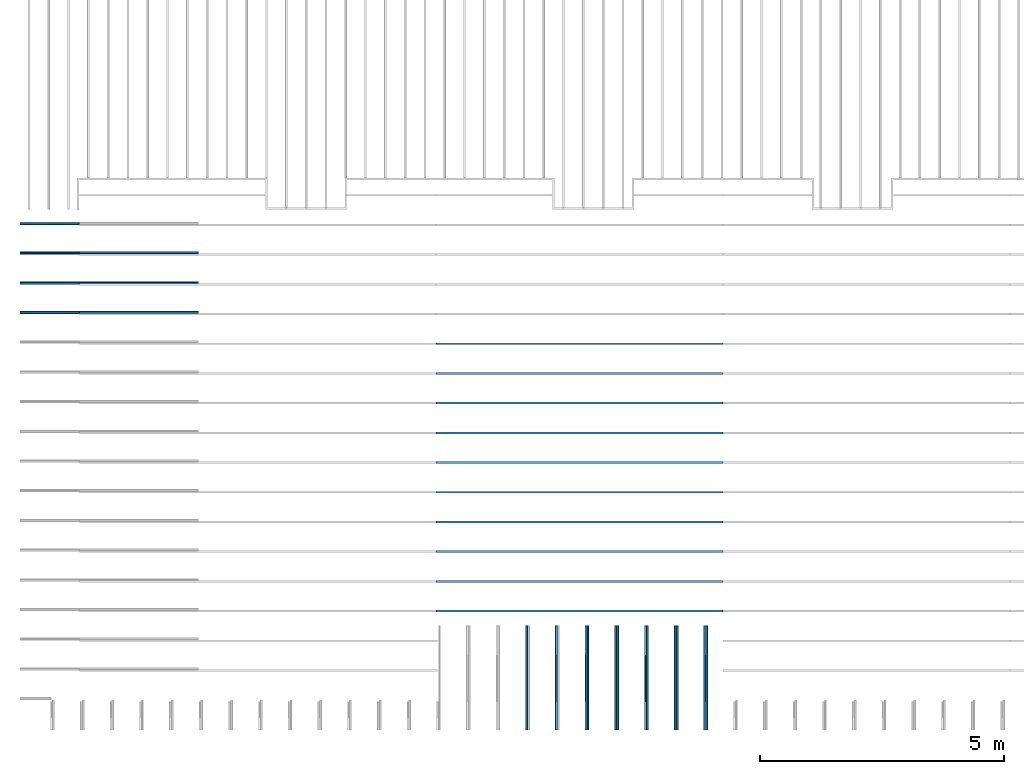
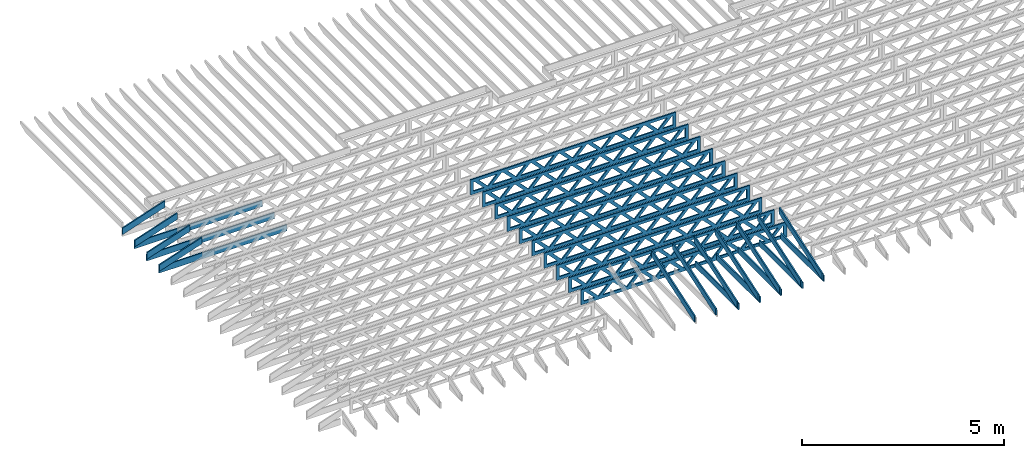
# One storey, part 3 of 17: 29 beams, 5 elements without a shape of their own.
"""IFC4 building model written with IfcOpenShell, lengths in feet."""

from ifc_helpers import new_model, entity, si_unit, converted_unit, derived_unit, direction, frame, frame_2d, origin, origin_2d_with_axis, place, context, subcontext, project, spatial, rectangle, extrude, clip, halfspace, source, transform, mapped, material, material_profile, profile_set, profile_usage, type_object, type_shapes, element, aggregate, save


model = new_model("IFC4")

# Units and contexts
model_context = context("Model", 3, precision=0.0001, world=origin(), true_north=direction((6.12303176911189e-17, 1.0)))
body_context = subcontext(model_context, "Body", "Model", "MODEL_VIEW")
ifc_project = project(units=[converted_unit("LENGTHUNIT", "FOOT", entity("IfcRatioMeasure", 0.3048), si_unit("LENGTHUNIT", "METRE"), dimensions=[1, 0, 0, 0, 0, 0, 0]), converted_unit("AREAUNIT", "SQUARE FOOT", entity("IfcRatioMeasure", 0.09290304), si_unit("AREAUNIT", "SQUARE_METRE"), dimensions=[2, 0, 0, 0, 0, 0, 0]), converted_unit("VOLUMEUNIT", "CUBIC FOOT", entity("IfcRatioMeasure", 0.028316846592), si_unit("VOLUMEUNIT", "CUBIC_METRE"), dimensions=[3, 0, 0, 0, 0, 0, 0]), converted_unit("PLANEANGLEUNIT", "DEGREE", entity("IfcRatioMeasure", 0.0174532925199433), si_unit("PLANEANGLEUNIT", "RADIAN"), dimensions=[0, 0, 0, 0, 0, 0, 0]), si_unit("MASSUNIT", "GRAM", prefix="KILO"), derived_unit("MASSDENSITYUNIT", [(si_unit("MASSUNIT", "GRAM", prefix="KILO"), 1), (si_unit("LENGTHUNIT", "METRE"), -3)]), derived_unit("MOMENTOFINERTIAUNIT", [(si_unit("LENGTHUNIT", "METRE"), 4)]), si_unit("TIMEUNIT", "SECOND"), si_unit("FREQUENCYUNIT", "HERTZ"), si_unit("THERMODYNAMICTEMPERATUREUNIT", "DEGREE_CELSIUS"), derived_unit("THERMALTRANSMITTANCEUNIT", [(si_unit("MASSUNIT", "GRAM", prefix="KILO"), 1), (si_unit("THERMODYNAMICTEMPERATUREUNIT", "KELVIN"), -1), (si_unit("TIMEUNIT", "SECOND"), -3)]), derived_unit("VOLUMETRICFLOWRATEUNIT", [(si_unit("LENGTHUNIT", "METRE"), 3), (si_unit("TIMEUNIT", "SECOND"), -1)]), si_unit("ELECTRICCURRENTUNIT", "AMPERE"), si_unit("ELECTRICVOLTAGEUNIT", "VOLT"), si_unit("POWERUNIT", "WATT"), si_unit("FORCEUNIT", "NEWTON"), si_unit("ILLUMINANCEUNIT", "LUX"), si_unit("LUMINOUSFLUXUNIT", "LUMEN"), si_unit("LUMINOUSINTENSITYUNIT", "CANDELA"), derived_unit("USERDEFINED", [(si_unit("MASSUNIT", "GRAM", prefix="KILO"), -1), (si_unit("LENGTHUNIT", "METRE"), -2), (si_unit("TIMEUNIT", "SECOND"), 3), (si_unit("LUMINOUSFLUXUNIT", "LUMEN"), 1)]), derived_unit("LINEARVELOCITYUNIT", [(si_unit("LENGTHUNIT", "METRE"), 1), (si_unit("TIMEUNIT", "SECOND"), -1)]), si_unit("PRESSUREUNIT", "PASCAL"), derived_unit("USERDEFINED", [(si_unit("LENGTHUNIT", "METRE"), -2), (si_unit("MASSUNIT", "GRAM", prefix="KILO"), 1), (si_unit("TIMEUNIT", "SECOND"), -2)]), derived_unit("LINEARFORCEUNIT", [(si_unit("MASSUNIT", "GRAM", prefix="KILO"), 1), (si_unit("LENGTHUNIT", "METRE"), 1), (si_unit("TIMEUNIT", "SECOND"), -2), (si_unit("LENGTHUNIT", "METRE"), -1)]), derived_unit("PLANARFORCEUNIT", [(si_unit("MASSUNIT", "GRAM", prefix="KILO"), 1), (si_unit("LENGTHUNIT", "METRE"), 1), (si_unit("TIMEUNIT", "SECOND"), -2), (si_unit("LENGTHUNIT", "METRE"), -2)])], contexts=[model_context])

# Site, building, storey
site_placement = place(None, origin())
site = spatial("IfcSite", under=ifc_project, at=site_placement, CompositionType="ELEMENT")
building_placement = place(site_placement, origin())
building = spatial("IfcBuilding", under=site, at=building_placement, CompositionType="ELEMENT")
storey_placement = place(building_placement, frame((0.0, 0.0, 30.4375000000082)))
storey = spatial("IfcBuildingStorey", under=building, at=storey_placement, Name="ROOF", CompositionType="ELEMENT", Elevation=30.4375000000082)

# Assembly, beams
assembly_1_placement = place(storey_placement, origin())
assembly_1 = element("IfcElementAssembly", 1, at=assembly_1_placement, inside=storey, Name="Structural Beam System:Structural Framing System", ObjectType="Structural Beam System:Structural Framing System", AssemblyPlace="NOTDEFINED", PredefinedType="BEAM_GRID")
ifc_material_1 = material(Name="WOOD TRUSS", Category="Materials")
ifc_material_profile_1 = material_profile(ifc_material_1, rectangle(XDim=1.73473973950632, YDim=0.125, at=origin_2d_with_axis()))
ifc_material_profile_2 = material_profile(ifc_material_1, rectangle(XDim=1.73473973950633, YDim=0.125, at=frame_2d((-1.11022302462516e-16, 0.0), x_axis=(1.0, 0.0))))
ifc_material_profile_3 = material_profile(ifc_material_1, rectangle(XDim=1.73473973950632, YDim=0.125, at=origin_2d_with_axis()))
ifc_material_profile_4 = material_profile(ifc_material_1, rectangle(XDim=1.73473973950633, YDim=0.125, at=origin_2d_with_axis()))
ifc_material_profile_5 = material_profile(ifc_material_1, rectangle(XDim=1.73473973950632, YDim=0.125, at=frame_2d((-5.55111512312578e-17, 0.0), x_axis=(1.0, 0.0))))
ifc_material_profile_6 = material_profile(ifc_material_1, rectangle(XDim=1.73473973950633, YDim=0.125, at=frame_2d((-2.77555756156289e-16, 0.0), x_axis=(1.0, 0.0))))
ifc_material_profile_7 = material_profile(ifc_material_1, rectangle(XDim=1.73473973950632, YDim=0.125, at=frame_2d((-4.9960036108132e-16, 0.0), x_axis=(1.0, 0.0))))
ifc_material_profile_8 = material_profile(ifc_material_1, rectangle(XDim=1.73473973950633, YDim=0.125, at=frame_2d((4.44089209850063e-16, 0.0), x_axis=(1.0, 0.0))))
ifc_material_profile_9 = material_profile(ifc_material_1, rectangle(XDim=1.73473973950632, YDim=0.125, at=origin_2d_with_axis()))
ifc_material_profile_10 = material_profile(ifc_material_1, rectangle(XDim=1.73473973950633, YDim=0.125, at=frame_2d((-4.9960036108132e-16, 0.0), x_axis=(1.0, 0.0))))
ifc_material_profile_11 = material_profile(ifc_material_1, rectangle(XDim=0.291666666666664, YDim=0.125, at=frame_2d((-2.77555756156289e-17, 0.0), x_axis=(1.0, 0.0))))
ifc_material_profile_12 = material_profile(ifc_material_1, rectangle(XDim=0.291666666666628, YDim=0.124999999999995, at=frame_2d((-5.55111512312578e-17, 0.0), x_axis=(1.0, 0.0))))
ifc_material_profile_13 = material_profile(ifc_material_1, rectangle(XDim=0.916666666666666, YDim=0.125000000000003, at=frame_2d((-2.77555756156289e-17, 0.0), x_axis=(1.0, 0.0))))
ifc_material_profile_14 = material_profile(ifc_material_1, rectangle(XDim=0.916666666666651, YDim=0.125, at=frame_2d((-2.77555756156289e-17, 0.0), x_axis=(1.0, 0.0))))
ifc_profile_set_1 = profile_set([ifc_material_profile_1, ifc_material_profile_2, ifc_material_profile_3, ifc_material_profile_4, ifc_material_profile_5, ifc_material_profile_6, ifc_material_profile_7, ifc_material_profile_8, ifc_material_profile_9, ifc_material_profile_10, ifc_material_profile_11, ifc_material_profile_12, ifc_material_profile_13, ifc_material_profile_14])
ifc_profile_usage_1 = profile_usage(ifc_profile_set_1, cardinal=8)
beam_type_1 = type_object("IfcBeamType", PredefinedType="BEAM", material=ifc_profile_set_1)
shared_shape_1 = source(origin(), body_context, "Body", "SweptSolid", [
    extrude(rectangle(XDim=1.73473973950632, YDim=0.125, at=frame_2d((-5.55111512312578e-16, 0.0), x_axis=(1.0, 0.0))), frame((5.85339326404794, 0.0, 0.101118361020562), z_axis=(0.720569184836762, 0.0, -0.693383046997606), x_axis=(0.693383046997606, 0.0, 0.720569184836762)), (0.0, 0.0, 1.0), 0.291666666666667),
    extrude(rectangle(XDim=1.73473973950633, YDim=0.125, at=frame_2d((-4.9960036108132e-16, 0.0), x_axis=(1.0, 0.0))), frame((4.60310739037467, 0.0, -0.101118361020407), z_axis=(0.720569184836758, 0.0, 0.69338304699761), x_axis=(0.69338304699761, 0.0, -0.720569184836758)), (0.0, 0.0, 1.0), 0.291666666666667),
    extrude(rectangle(XDim=1.73473973950632, YDim=0.125, at=frame_2d((3.33066907387547e-16, 0.0), x_axis=(1.0, 0.0))), frame((3.18672659738144, 0.0, 0.101118361020562), z_axis=(0.720569184836762, 0.0, -0.693383046997606), x_axis=(0.693383046997606, 0.0, 0.720569184836762)), (0.0, 0.0, 1.0), 0.291666666666667),
    extrude(rectangle(XDim=1.73473973950633, YDim=0.125, at=frame_2d((-1.11022302462516e-16, 0.0), x_axis=(1.0, 0.0))), frame((1.93644072370817, 0.0, -0.101118361020407), z_axis=(0.720569184836758, 0.0, 0.69338304699761), x_axis=(0.69338304699761, 0.0, -0.720569184836758)), (0.0, 0.0, 1.0), 0.291666666666666),
    extrude(rectangle(XDim=1.73473973950632, YDim=0.125, at=frame_2d((5.55111512312578e-17, 0.0), x_axis=(1.0, 0.0))), frame((0.520059930714937, 0.0, 0.101118361020562), z_axis=(0.720569184836762, 0.0, -0.693383046997606), x_axis=(0.693383046997606, 0.0, 0.720569184836762)), (0.0, 0.0, 1.0), 0.291666666666667),
    extrude(rectangle(XDim=1.73473973950633, YDim=0.125, at=origin_2d_with_axis()), frame((-0.730225942958334, 0.0, -0.101118361020407), z_axis=(0.720569184836758, 0.0, 0.69338304699761), x_axis=(0.69338304699761, 0.0, -0.720569184836758)), (0.0, 0.0, 1.0), 0.291666666666666),
    extrude(rectangle(XDim=1.73473973950632, YDim=0.125, at=frame_2d((-5.55111512312578e-17, 0.0), x_axis=(1.0, 0.0))), frame((-2.14660673595157, 0.0, 0.101118361020562), z_axis=(0.720569184836762, 0.0, -0.693383046997606), x_axis=(0.693383046997606, 0.0, 0.720569184836762)), (0.0, 0.0, 1.0), 0.291666666666667),
    extrude(rectangle(XDim=1.73473973950633, YDim=0.125, at=frame_2d((-2.77555756156289e-16, 0.0), x_axis=(1.0, 0.0))), frame((-3.39689260962484, 0.0, -0.101118361020407), z_axis=(0.720569184836758, 0.0, 0.69338304699761), x_axis=(0.69338304699761, 0.0, -0.720569184836758)), (0.0, 0.0, 1.0), 0.291666666666666),
    extrude(rectangle(XDim=1.73473973950632, YDim=0.125, at=origin_2d_with_axis()), frame((-4.81327340261807, 0.0, 0.101118361020562), z_axis=(0.720569184836762, 0.0, -0.693383046997606), x_axis=(0.693383046997606, 0.0, 0.720569184836762)), (0.0, 0.0, 1.0), 0.291666666666667),
    extrude(rectangle(XDim=1.73473973950633, YDim=0.125, at=frame_2d((-4.9960036108132e-16, 0.0), x_axis=(1.0, 0.0))), frame((-6.06355927629134, 0.0, -0.101118361020407), z_axis=(0.720569184836758, 0.0, 0.69338304699761), x_axis=(0.69338304699761, 0.0, -0.720569184836758)), (0.0, 0.0, 1.0), 0.291666666666667),
    extrude(rectangle(XDim=1.73473973950632, YDim=0.125, at=frame_2d((-1.0547118733939e-15, 0.0), x_axis=(1.0, 0.0))), frame((8.52005993071445, 0.0, 0.101118361020506), z_axis=(0.720569184836761, 0.0, -0.693383046997607), x_axis=(0.693383046997607, 0.0, 0.720569184836761)), (0.0, 0.0, 1.0), 0.291666666666667),
    extrude(rectangle(XDim=1.73473973950633, YDim=0.125, at=origin_2d_with_axis()), frame((7.26977405704118, 0.0, -0.101118361020463), z_axis=(0.720569184836758, 0.0, 0.69338304699761), x_axis=(0.69338304699761, 0.0, -0.720569184836758)), (0.0, 0.0, 1.0), 0.291666666666667),
    extrude(rectangle(XDim=1.73473973950632, YDim=0.125, at=frame_2d((4.44089209850063e-16, 0.0), x_axis=(1.0, 0.0))), frame((-7.47994006928457, 0.0, 0.101118361020561), z_axis=(0.720569184836762, 0.0, -0.693383046997606), x_axis=(0.693383046997606, 0.0, 0.720569184836762)), (0.0, 0.0, 1.0), 0.291666666666666),
    extrude(rectangle(XDim=1.73473973950633, YDim=0.125, at=origin_2d_with_axis()), frame((-8.73022594295784, 0.0, -0.101118361020408), z_axis=(0.720569184836758, 0.0, 0.69338304699761), x_axis=(0.69338304699761, 0.0, -0.720569184836758)), (0.0, 0.0, 1.0), 0.291666666666666),
    extrude(rectangle(XDim=0.291666666666664, YDim=0.125, at=frame_2d((-2.77555756156289e-17, 0.0), x_axis=(1.0, 0.0))), frame((-9.66666666666609, 0.0, 0.604166666666611), z_axis=(1.0, 0.0, 0.0), x_axis=(0.0, 0.0, -1.0)), (0.0, 0.0, 1.0), 19.3333333333322),
    extrude(rectangle(XDim=0.291666666666628, YDim=0.124999999999995, at=frame_2d((-5.55111512312578e-17, 0.0), x_axis=(1.0, 0.0))), frame((-9.66666666666588, 0.0, -0.604166666666693), z_axis=(1.0, 0.0, 0.0), x_axis=(0.0, 0.0, -1.0)), (0.0, 0.0, 1.0), 19.333333333332),
    extrude(rectangle(XDim=0.916666666666666, YDim=0.125000000000003, at=frame_2d((-2.77555756156289e-17, 0.0), x_axis=(1.0, 0.0))), frame((9.3749999999994, 0.0, 0.0), z_axis=(1.0, 0.0, 0.0), x_axis=(0.0, 0.0, -1.0)), (0.0, 0.0, 1.0), 0.291666666666687),
    extrude(rectangle(XDim=0.916666666666651, YDim=0.125, at=frame_2d((-2.77555756156289e-17, 0.0), x_axis=(1.0, 0.0))), frame((-9.66666666666609, 0.0, 0.0), z_axis=(1.0, 0.0, 0.0), x_axis=(0.0, 0.0, -1.0)), (0.0, 0.0, 1.0), 0.291666666666687),
])
type_shapes(beam_type_1, [shared_shape_1])
beam_1_placement = place(assembly_1_placement, frame((-232.071493818828, 947.861934882651, 0.74999999999163)))
beam_1 = element("IfcBeam", 2, at=beam_1_placement, type_object=beam_type_1, material=ifc_profile_usage_1, PredefinedType="BEAM", context=body_context, shape_type="MappedRepresentation", body=[
    mapped(shared_shape_1, transform((0.0, 0.0, 0.0), scale=1.0)),
])
ifc_profile_usage_2 = profile_usage(ifc_profile_set_1, cardinal=8)
beam_2_placement = place(assembly_1_placement, frame((-232.071493818828, 945.861934882651, 0.749999999991637)))
beam_2 = element("IfcBeam", 3, at=beam_2_placement, type_object=beam_type_1, material=ifc_profile_usage_2, PredefinedType="BEAM", context=body_context, shape_type="MappedRepresentation", body=[
    mapped(shared_shape_1, transform((0.0, 0.0, 0.0), scale=1.0)),
])
ifc_profile_usage_3 = profile_usage(ifc_profile_set_1, cardinal=8)
beam_3_placement = place(assembly_1_placement, frame((-232.071493818828, 943.861934882651, 0.749999999991644)))
beam_3 = element("IfcBeam", 4, at=beam_3_placement, type_object=beam_type_1, material=ifc_profile_usage_3, PredefinedType="BEAM", context=body_context, shape_type="MappedRepresentation", body=[
    mapped(shared_shape_1, transform((0.0, 0.0, 0.0), scale=1.0)),
])
ifc_profile_usage_4 = profile_usage(ifc_profile_set_1, cardinal=8)
beam_4_placement = place(assembly_1_placement, frame((-232.071493818828, 941.861934882651, 0.749999999991651)))
beam_4 = element("IfcBeam", 5, at=beam_4_placement, type_object=beam_type_1, material=ifc_profile_usage_4, PredefinedType="BEAM", context=body_context, shape_type="MappedRepresentation", body=[
    mapped(shared_shape_1, transform((0.0, 0.0, 0.0), scale=1.0)),
])
ifc_profile_usage_5 = profile_usage(ifc_profile_set_1, cardinal=8)
beam_5_placement = place(assembly_1_placement, frame((-232.071493818828, 939.861934882651, 0.749999999991651)))
beam_5 = element("IfcBeam", 6, at=beam_5_placement, type_object=beam_type_1, material=ifc_profile_usage_5, PredefinedType="BEAM", context=body_context, shape_type="MappedRepresentation", body=[
    mapped(shared_shape_1, transform((0.0, 0.0, 0.0), scale=1.0)),
])
ifc_profile_usage_6 = profile_usage(ifc_profile_set_1, cardinal=8)
beam_6_placement = place(assembly_1_placement, frame((-232.071493818828, 937.861934882651, 0.749999999991658)))
beam_6 = element("IfcBeam", 7, at=beam_6_placement, type_object=beam_type_1, material=ifc_profile_usage_6, PredefinedType="BEAM", context=body_context, shape_type="MappedRepresentation", body=[
    mapped(shared_shape_1, transform((0.0, 0.0, 0.0), scale=1.0)),
])
ifc_profile_usage_7 = profile_usage(ifc_profile_set_1, cardinal=8)
beam_7_placement = place(assembly_1_placement, frame((-232.071493818828, 935.861934882651, 0.749999999991665)))
beam_7 = element("IfcBeam", 8, at=beam_7_placement, type_object=beam_type_1, material=ifc_profile_usage_7, PredefinedType="BEAM", context=body_context, shape_type="MappedRepresentation", body=[
    mapped(shared_shape_1, transform((0.0, 0.0, 0.0), scale=1.0)),
])
ifc_profile_usage_8 = profile_usage(ifc_profile_set_1, cardinal=8)
beam_8_placement = place(assembly_1_placement, frame((-232.071493818828, 933.861934882651, 0.749999999991672)))
beam_8 = element("IfcBeam", 9, at=beam_8_placement, type_object=beam_type_1, material=ifc_profile_usage_8, PredefinedType="BEAM", context=body_context, shape_type="MappedRepresentation", body=[
    mapped(shared_shape_1, transform((0.0, 0.0, 0.0), scale=1.0)),
])
ifc_profile_usage_9 = profile_usage(ifc_profile_set_1, cardinal=8)
beam_9_placement = place(assembly_1_placement, frame((-232.071493818828, 931.861934882651, 0.74999999999168)))
beam_9 = element("IfcBeam", 10, at=beam_9_placement, type_object=beam_type_1, material=ifc_profile_usage_9, PredefinedType="BEAM", context=body_context, shape_type="MappedRepresentation", body=[
    mapped(shared_shape_1, transform((0.0, 0.0, 0.0), scale=1.0)),
])
ifc_profile_usage_10 = profile_usage(ifc_profile_set_1, cardinal=8)
beam_10_placement = place(assembly_1_placement, frame((-232.071493818828, 929.861934882651, 0.74999999999168)))
beam_10 = element("IfcBeam", 11, at=beam_10_placement, type_object=beam_type_1, material=ifc_profile_usage_10, PredefinedType="BEAM", context=body_context, shape_type="MappedRepresentation", body=[
    mapped(shared_shape_1, transform((0.0, 0.0, 0.0), scale=1.0)),
])
aggregate(assembly_1, [beam_1, beam_2, beam_3, beam_4, beam_5, beam_6, beam_7, beam_8, beam_9, beam_10])

assembly_2_placement = place(storey_placement, origin())
assembly_2 = element("IfcElementAssembly", 12, at=assembly_2_placement, inside=storey, Name="Structural Beam System:Structural Framing System", ObjectType="Structural Beam System:Structural Framing System", AssemblyPlace="NOTDEFINED", PredefinedType="BEAM_GRID")
ifc_material_2 = material(Name="BOTTOM CHORD OF FIELD FRAMED OVERHANG", Category="Materials")
ifc_material_profile_15 = material_profile(ifc_material_2, rectangle(XDim=0.604166666666667, YDim=0.125000000000011, at=origin_2d_with_axis()), Name="2X8 - BOTTOM CHORD")
ifc_profile_set_2 = profile_set([ifc_material_profile_15], Name="2X8 - BOTTOM CHORD")
ifc_profile_usage_11 = profile_usage(ifc_profile_set_2, cardinal=8)
beam_type_2 = type_object("IfcBeamType", Name="061100 - Wood Framing:2X8 - BOTTOM CHORD", PredefinedType="BEAM", material=ifc_profile_set_2)
shared_shape_2 = source(origin(), body_context, "Body", "SweptSolid", [
    extrude(rectangle(XDim=0.604166666666667, YDim=0.125000000000011, at=origin_2d_with_axis()), frame((-3.49999999999926, 0.0, 0.0), z_axis=(1.0, 0.0, 0.0), x_axis=(0.0, 0.0, -1.0)), (0.0, 0.0, 1.0), 6.99999999999852),
])
type_shapes(beam_type_2, [shared_shape_2])
beam_11_placement = place(assembly_2_placement, frame((-223.488158437574, 925.361929752809, 1.07291666665406), z_axis=(0.0, 0.0, 1.0), x_axis=(0.0, -1.0, 0.0)))
beam_11 = element("IfcBeam", 13, at=beam_11_placement, type_object=beam_type_2, material=ifc_profile_usage_11, Name="061100 - Wood Framing:2X8 - BOTTOM CHORD", ObjectType="061100 - Wood Framing:2X8 - BOTTOM CHORD", PredefinedType="BEAM", context=body_context, shape_type="MappedRepresentation", body=[
    mapped(shared_shape_2, transform((0.0, 0.0, 0.0), scale=1.0)),
])
ifc_profile_usage_12 = profile_usage(ifc_profile_set_2, cardinal=8)
beam_12_placement = place(assembly_2_placement, frame((-225.488158437574, 925.361929250305, 1.07291666665406), z_axis=(0.0, 0.0, 1.0), x_axis=(0.0, -1.0, 0.0)))
beam_12 = element("IfcBeam", 14, at=beam_12_placement, type_object=beam_type_2, material=ifc_profile_usage_12, Name="061100 - Wood Framing:2X8 - BOTTOM CHORD", ObjectType="061100 - Wood Framing:2X8 - BOTTOM CHORD", PredefinedType="BEAM", context=body_context, shape_type="MappedRepresentation", body=[
    mapped(shared_shape_2, transform((0.0, 0.0, 0.0), scale=1.0)),
])
ifc_profile_usage_13 = profile_usage(ifc_profile_set_2, cardinal=8)
beam_13_placement = place(assembly_2_placement, frame((-227.488158437574, 925.361928747801, 1.07291666665406), z_axis=(0.0, 0.0, 1.0), x_axis=(0.0, -1.0, 0.0)))
beam_13 = element("IfcBeam", 15, at=beam_13_placement, type_object=beam_type_2, material=ifc_profile_usage_13, Name="061100 - Wood Framing:2X8 - BOTTOM CHORD", ObjectType="061100 - Wood Framing:2X8 - BOTTOM CHORD", PredefinedType="BEAM", context=body_context, shape_type="MappedRepresentation", body=[
    mapped(shared_shape_2, transform((0.0, 0.0, 0.0), scale=1.0)),
])
ifc_profile_usage_14 = profile_usage(ifc_profile_set_2, cardinal=8)
beam_14_placement = place(assembly_2_placement, frame((-229.488158437574, 925.361928245297, 1.07291666665406), z_axis=(0.0, 0.0, 1.0), x_axis=(0.0, -1.0, 0.0)))
beam_14 = element("IfcBeam", 16, at=beam_14_placement, type_object=beam_type_2, material=ifc_profile_usage_14, Name="061100 - Wood Framing:2X8 - BOTTOM CHORD", ObjectType="061100 - Wood Framing:2X8 - BOTTOM CHORD", PredefinedType="BEAM", context=body_context, shape_type="MappedRepresentation", body=[
    mapped(shared_shape_2, transform((0.0, 0.0, 0.0), scale=1.0)),
])
ifc_profile_usage_15 = profile_usage(ifc_profile_set_2, cardinal=8)
beam_15_placement = place(assembly_2_placement, frame((-231.488158437574, 925.361927742794, 1.07291666665406), z_axis=(0.0, 0.0, 1.0), x_axis=(0.0, -1.0, 0.0)))
beam_15 = element("IfcBeam", 17, at=beam_15_placement, type_object=beam_type_2, material=ifc_profile_usage_15, Name="061100 - Wood Framing:2X8 - BOTTOM CHORD", ObjectType="061100 - Wood Framing:2X8 - BOTTOM CHORD", PredefinedType="BEAM", context=body_context, shape_type="MappedRepresentation", body=[
    mapped(shared_shape_2, transform((0.0, 0.0, 0.0), scale=1.0)),
])
aggregate(assembly_2, [beam_11, beam_12, beam_13, beam_14, beam_15])

assembly_3_placement = place(storey_placement, origin())
assembly_3 = element("IfcElementAssembly", 18, at=assembly_3_placement, inside=storey, Name="Structural Beam System:Structural Framing System", ObjectType="Structural Beam System:Structural Framing System", AssemblyPlace="NOTDEFINED", PredefinedType="BEAM_GRID")
ifc_material_3 = material(Name="TOP CHORD OF FIELD FRAMED OVERHANG", Category="Materials")
ifc_material_profile_16 = material_profile(ifc_material_3, rectangle(XDim=0.604166666666667, YDim=0.125, at=origin_2d_with_axis()), Name="2X8 TOP CHORD")
ifc_profile_set_3 = profile_set([ifc_material_profile_16], Name="2X8 TOP CHORD")
ifc_profile_usage_16 = profile_usage(ifc_profile_set_3, cardinal=8)
beam_type_3 = type_object("IfcBeamType", Name="Dimension Lumber - Ends:2X8 TOP CHORD", PredefinedType="BEAM", material=ifc_profile_set_3)
shared_shape_3 = source(origin(), body_context, "Body", "Clipping", [
    clip(clip(extrude(rectangle(XDim=0.604166666666667, YDim=0.125, at=origin_2d_with_axis()), frame((-3.68932423085928, 0.0, 0.0), z_axis=(1.0, 0.0, 0.0), x_axis=(0.0, 0.0, -1.0)), (0.0, 0.0, 1.0), 7.57997937023103), halfspace(frame((3.68932423085925, -0.0625000000000025, -0.302083333333339), z_axis=(0.948710608132914, 0.0, -0.316145823973806), x_axis=(0.0, 1.0, 0.0)), False)), halfspace(frame((-3.4879933223468, -0.0625000000000025, 0.302083333333328), z_axis=(-0.948710608132914, 0.0, 0.316145823973805), x_axis=(0.0, 1.0, 0.0)), False)),
])
type_shapes(beam_type_3, [shared_shape_3])
beam_16_placement = place(assembly_3_placement, frame((-223.613158541547, 925.266392269532, 2.43688759934747), z_axis=(0.0, -0.316227766016851, 0.94868329805051), x_axis=(0.0, 0.94868329805051, 0.316227766016851)))
beam_16 = element("IfcBeam", 19, at=beam_16_placement, type_object=beam_type_3, material=ifc_profile_usage_16, Name="Dimension Lumber - Ends:2X8 TOP CHORD", ObjectType="Dimension Lumber - Ends:2X8 TOP CHORD", PredefinedType="BEAM", context=body_context, shape_type="MappedRepresentation", body=[
    mapped(shared_shape_3, transform((0.0, 0.0, 0.0), scale=1.0)),
])
ifc_profile_usage_17 = profile_usage(ifc_profile_set_3, cardinal=8)
beam_17_placement = place(assembly_3_placement, frame((-225.613158541547, 925.266392269532, 2.43688759934747), z_axis=(0.0, -0.316227766016851, 0.94868329805051), x_axis=(0.0, 0.94868329805051, 0.316227766016851)))
beam_17 = element("IfcBeam", 20, at=beam_17_placement, type_object=beam_type_3, material=ifc_profile_usage_17, Name="Dimension Lumber - Ends:2X8 TOP CHORD", ObjectType="Dimension Lumber - Ends:2X8 TOP CHORD", PredefinedType="BEAM", context=body_context, shape_type="MappedRepresentation", body=[
    mapped(shared_shape_3, transform((0.0, 0.0, 0.0), scale=1.0)),
])
ifc_profile_usage_18 = profile_usage(ifc_profile_set_3, cardinal=8)
beam_18_placement = place(assembly_3_placement, frame((-227.613158541547, 925.266392269532, 2.43688759934741), z_axis=(0.0, -0.316227766016852, 0.948683298050509), x_axis=(0.0, 0.948683298050509, 0.316227766016852)))
beam_18 = element("IfcBeam", 21, at=beam_18_placement, type_object=beam_type_3, material=ifc_profile_usage_18, Name="Dimension Lumber - Ends:2X8 TOP CHORD", ObjectType="Dimension Lumber - Ends:2X8 TOP CHORD", PredefinedType="BEAM", context=body_context, shape_type="MappedRepresentation", body=[
    mapped(shared_shape_3, transform((0.0, 0.0, 0.0), scale=1.0)),
])
ifc_profile_usage_19 = profile_usage(ifc_profile_set_3, cardinal=8)
beam_19_placement = place(assembly_3_placement, frame((-229.613158541547, 925.266392269532, 2.43688759934759), z_axis=(0.0, -0.316227766016851, 0.948683298050509), x_axis=(0.0, 0.948683298050509, 0.316227766016851)))
beam_19 = element("IfcBeam", 22, at=beam_19_placement, type_object=beam_type_3, material=ifc_profile_usage_19, Name="Dimension Lumber - Ends:2X8 TOP CHORD", ObjectType="Dimension Lumber - Ends:2X8 TOP CHORD", PredefinedType="BEAM", context=body_context, shape_type="MappedRepresentation", body=[
    mapped(shared_shape_3, transform((0.0, 0.0, 0.0), scale=1.0)),
])
ifc_profile_usage_20 = profile_usage(ifc_profile_set_3, cardinal=8)
beam_20_placement = place(assembly_3_placement, frame((-231.613158541547, 925.266392269532, 2.43688759934747), z_axis=(0.0, -0.316227766016852, 0.948683298050509), x_axis=(0.0, 0.948683298050509, 0.316227766016852)))
beam_20 = element("IfcBeam", 23, at=beam_20_placement, type_object=beam_type_3, material=ifc_profile_usage_20, Name="Dimension Lumber - Ends:2X8 TOP CHORD", ObjectType="Dimension Lumber - Ends:2X8 TOP CHORD", PredefinedType="BEAM", context=body_context, shape_type="MappedRepresentation", body=[
    mapped(shared_shape_3, transform((0.0, 0.0, 0.0), scale=1.0)),
])
ifc_profile_usage_21 = profile_usage(ifc_profile_set_3, cardinal=8)
beam_21_placement = place(assembly_3_placement, frame((-233.613158541548, 925.266392269532, 2.43688759934747), z_axis=(0.0, -0.316227766016848, 0.948683298050511), x_axis=(0.0, 0.948683298050511, 0.316227766016848)))
beam_21 = element("IfcBeam", 24, at=beam_21_placement, type_object=beam_type_3, material=ifc_profile_usage_21, Name="Dimension Lumber - Ends:2X8 TOP CHORD", ObjectType="Dimension Lumber - Ends:2X8 TOP CHORD", PredefinedType="BEAM", context=body_context, shape_type="MappedRepresentation", body=[
    mapped(shared_shape_3, transform((0.0, 0.0, 0.0), scale=1.0)),
])
ifc_profile_usage_22 = profile_usage(ifc_profile_set_3, cardinal=8)
beam_22_placement = place(assembly_3_placement, frame((-235.613158541548, 925.266392269532, 2.43688759934747), z_axis=(0.0, -0.316227766016848, 0.948683298050511), x_axis=(0.0, 0.948683298050511, 0.316227766016848)))
beam_22 = element("IfcBeam", 25, at=beam_22_placement, type_object=beam_type_3, material=ifc_profile_usage_22, Name="Dimension Lumber - Ends:2X8 TOP CHORD", ObjectType="Dimension Lumber - Ends:2X8 TOP CHORD", PredefinedType="BEAM", context=body_context, shape_type="MappedRepresentation", body=[
    mapped(shared_shape_3, transform((0.0, 0.0, 0.0), scale=1.0)),
])
aggregate(assembly_3, [beam_16, beam_17, beam_18, beam_19, beam_20, beam_21, beam_22])

assembly_4_placement = place(storey_placement, origin())
assembly_4 = element("IfcElementAssembly", 26, at=assembly_4_placement, inside=storey, Name="Structural Beam System:Structural Framing System", ObjectType="Structural Beam System:Structural Framing System", AssemblyPlace="NOTDEFINED", PredefinedType="BEAM_GRID")
ifc_material_4 = material(Name="2X8 TO ROOF", Category="Materials")
ifc_material_profile_17 = material_profile(ifc_material_4, rectangle(XDim=0.604166666666667, YDim=0.125000000000011, at=origin_2d_with_axis()), Name="2X8")
ifc_profile_set_4 = profile_set([ifc_material_profile_17], Name="2X8")
ifc_profile_usage_23 = profile_usage(ifc_profile_set_4, cardinal=8)
beam_type_4 = type_object("IfcBeamType", Name="061100 - Wood Framing:2X8", PredefinedType="BEAM", material=ifc_profile_set_4)
shared_shape_4 = source(origin(), body_context, "Body", "SweptSolid", [
    extrude(rectangle(XDim=0.604166666666667, YDim=0.125000000000011, at=origin_2d_with_axis()), frame((-6.0, 0.0, 0.0), z_axis=(1.0, 0.0, 0.0), x_axis=(0.0, 0.0, -1.0)), (0.0, 0.0, 1.0), 12.000000000033),
])
type_shapes(beam_type_4, [shared_shape_4])
beam_23_placement = place(assembly_4_placement, frame((-263.738087916709, 949.986939927882, 1.07291666665841), z_axis=(0.0, 0.0, 1.0), x_axis=(-1.0, 0.0, 0.0)))
beam_23 = element("IfcBeam", 27, at=beam_23_placement, type_object=beam_type_4, material=ifc_profile_usage_23, Name="061100 - Wood Framing:2X8", ObjectType="061100 - Wood Framing:2X8", PredefinedType="BEAM", context=body_context, shape_type="MappedRepresentation", body=[
    mapped(shared_shape_4, transform((0.0, 0.0, 0.0), scale=1.0)),
])
ifc_profile_usage_24 = profile_usage(ifc_profile_set_4, cardinal=8)
beam_24_placement = place(assembly_4_placement, frame((-263.738072841597, 951.986939927996, 1.07291666665841), z_axis=(0.0, 0.0, 1.0), x_axis=(-1.0, 0.0, 0.0)))
beam_24 = element("IfcBeam", 28, at=beam_24_placement, type_object=beam_type_4, material=ifc_profile_usage_24, Name="061100 - Wood Framing:2X8", ObjectType="061100 - Wood Framing:2X8", PredefinedType="BEAM", context=body_context, shape_type="MappedRepresentation", body=[
    mapped(shared_shape_4, transform((0.0, 0.0, 0.0), scale=1.0)),
])
ifc_profile_usage_25 = profile_usage(ifc_profile_set_4, cardinal=8)
beam_25_placement = place(assembly_4_placement, frame((-263.738057766485, 953.98693992811, 1.0729166666584), z_axis=(0.0, 0.0, 1.0), x_axis=(-1.0, 0.0, 0.0)))
beam_25 = element("IfcBeam", 29, at=beam_25_placement, type_object=beam_type_4, material=ifc_profile_usage_25, Name="061100 - Wood Framing:2X8", ObjectType="061100 - Wood Framing:2X8", PredefinedType="BEAM", context=body_context, shape_type="MappedRepresentation", body=[
    mapped(shared_shape_4, transform((0.0, 0.0, 0.0), scale=1.0)),
])
aggregate(assembly_4, [beam_23, beam_24, beam_25])

assembly_5_placement = place(storey_placement, origin())
assembly_5 = element("IfcElementAssembly", 30, at=assembly_5_placement, inside=storey, Name="Structural Beam System:Structural Framing System", ObjectType="Structural Beam System:Structural Framing System", AssemblyPlace="NOTDEFINED", PredefinedType="BEAM_GRID")
ifc_profile_usage_26 = profile_usage(ifc_profile_set_3, cardinal=8)
beam_type_5 = type_object("IfcBeamType", Name="Dimension Lumber - Ends:2X8 TOP CHORD", PredefinedType="BEAM", material=ifc_profile_set_3)
shared_shape_5 = source(origin(), body_context, "Body", "Clipping", [
    clip(clip(extrude(rectangle(XDim=0.604166666666671, YDim=0.125, at=frame_2d((-1.83186799063151e-15, 0.0), x_axis=(1.0, 0.0))), frame((-2.10819527564865, 0.0, 0.0), z_axis=(1.0, 0.0, 0.0), x_axis=(0.0, 0.0, -1.0)), (0.0, 0.0, 1.0), 4.41772145980974), halfspace(frame((2.10819527564862, -0.0625000000000025, -0.302083333333339), z_axis=(0.948710608132914, 0.0, -0.316145823973807), x_axis=(0.0, 1.0, 0.0)), False)), halfspace(frame((-1.90686436713617, -0.0625000000000025, 0.302083333333328), z_axis=(-0.948710608132914, 0.0, 0.316145823973807), x_axis=(0.0, 1.0, 0.0)), False)),
])
type_shapes(beam_type_5, [shared_shape_5])
beam_26_placement = place(assembly_5_placement, frame((-267.833654839365, 949.945265019167, 1.93690371042362), z_axis=(-0.316227766016838, 0.0, 0.948683298050514), x_axis=(0.948683298050514, 0.0, 0.316227766016837)))
beam_26 = element("IfcBeam", 31, at=beam_26_placement, type_object=beam_type_5, material=ifc_profile_usage_26, Name="Dimension Lumber - Ends:2X8 TOP CHORD", ObjectType="Dimension Lumber - Ends:2X8 TOP CHORD", PredefinedType="BEAM", context=body_context, shape_type="MappedRepresentation", body=[
    mapped(shared_shape_5, transform((0.0, 0.0, 0.0), scale=1.0)),
])
ifc_profile_usage_27 = profile_usage(ifc_profile_set_3, cardinal=8)
beam_27_placement = place(assembly_5_placement, frame((-267.833654839365, 951.945265019167, 1.93690371042362), z_axis=(-0.316227766016838, 0.0, 0.948683298050514), x_axis=(0.948683298050514, 0.0, 0.316227766016837)))
beam_27 = element("IfcBeam", 32, at=beam_27_placement, type_object=beam_type_5, material=ifc_profile_usage_27, Name="Dimension Lumber - Ends:2X8 TOP CHORD", ObjectType="Dimension Lumber - Ends:2X8 TOP CHORD", PredefinedType="BEAM", context=body_context, shape_type="MappedRepresentation", body=[
    mapped(shared_shape_5, transform((0.0, 0.0, 0.0), scale=1.0)),
])
ifc_profile_usage_28 = profile_usage(ifc_profile_set_3, cardinal=8)
beam_28_placement = place(assembly_5_placement, frame((-267.833654839365, 953.945265019167, 1.93690371042362), z_axis=(-0.316227766016838, 0.0, 0.948683298050514), x_axis=(0.948683298050514, 0.0, 0.316227766016837)))
beam_28 = element("IfcBeam", 33, at=beam_28_placement, type_object=beam_type_5, material=ifc_profile_usage_28, Name="Dimension Lumber - Ends:2X8 TOP CHORD", ObjectType="Dimension Lumber - Ends:2X8 TOP CHORD", PredefinedType="BEAM", context=body_context, shape_type="MappedRepresentation", body=[
    mapped(shared_shape_5, transform((0.0, 0.0, 0.0), scale=1.0)),
])
ifc_profile_usage_29 = profile_usage(ifc_profile_set_3, cardinal=8)
beam_29_placement = place(assembly_5_placement, frame((-267.833654839365, 955.945265019167, 1.93690371042362), z_axis=(-0.316227766016838, 0.0, 0.948683298050514), x_axis=(0.948683298050514, 0.0, 0.316227766016837)))
beam_29 = element("IfcBeam", 34, at=beam_29_placement, type_object=beam_type_5, material=ifc_profile_usage_29, Name="Dimension Lumber - Ends:2X8 TOP CHORD", ObjectType="Dimension Lumber - Ends:2X8 TOP CHORD", PredefinedType="BEAM", context=body_context, shape_type="MappedRepresentation", body=[
    mapped(shared_shape_5, transform((0.0, 0.0, 0.0), scale=1.0)),
])
aggregate(assembly_5, [beam_26, beam_27, beam_28, beam_29])

save(model, "model.ifc")
